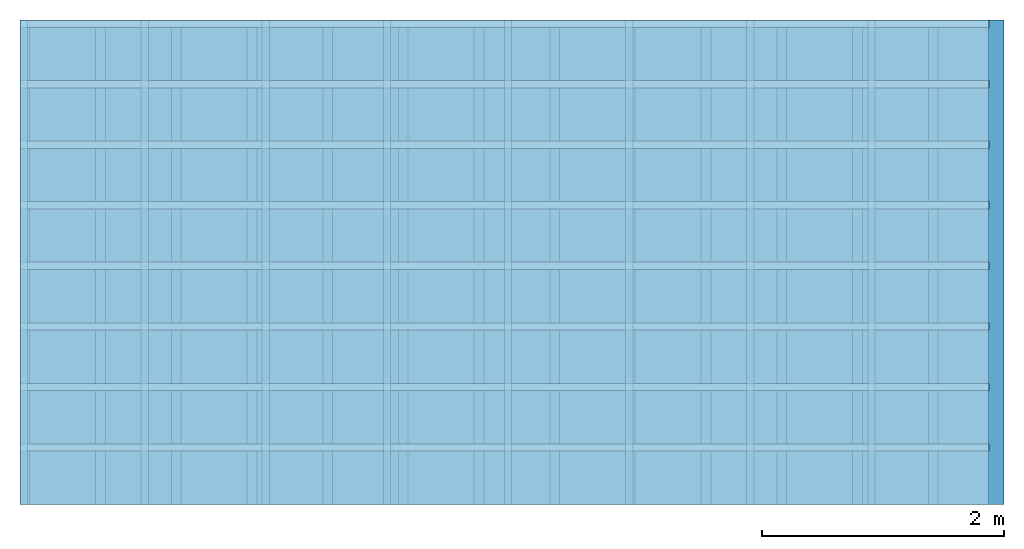
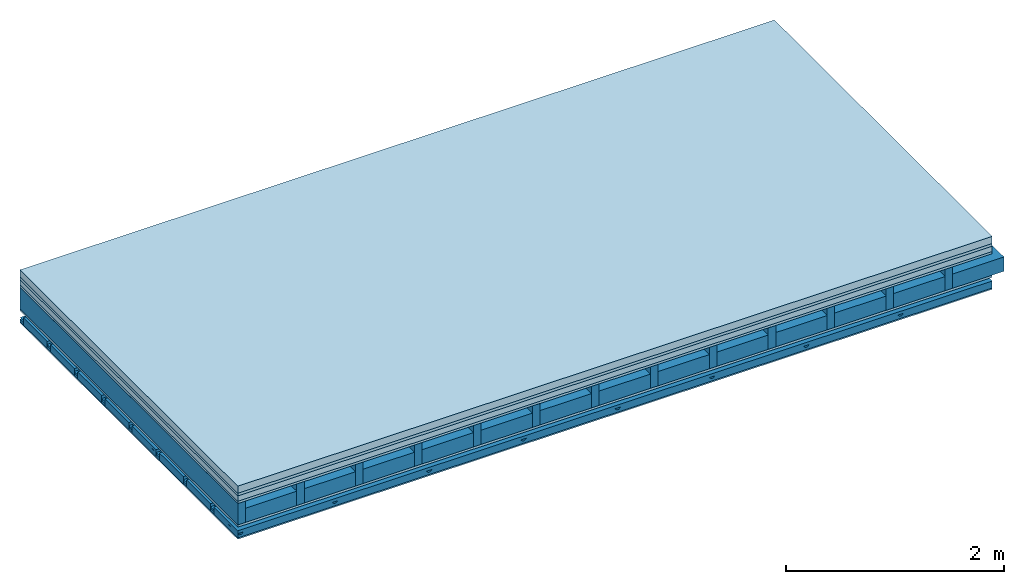
# One storey: 6 plates, 5 members, 1 element without a shape of its own.
"""IFC4 building model written with IfcOpenShell, lengths in metres."""

from ifc_helpers import new_model, si_unit, derived_unit, direction, frame, frame_2d, origin, origin_with_axes, place, context, project, spatial, polyline, rectangle, outline, extrude, material, layer, layer_set, type_object, element, aggregate, save


model = new_model("IFC4")

# Units and contexts
plan_context = context("Plan", 3, precision=1e-05, world=origin(), true_north=direction((0.0, 1.0)))
model_context = context("Model", 3, precision=1e-05, world=origin(), true_north=direction((0.0, 1.0)))
ifc_project = project(units=[si_unit("LENGTHUNIT", "METRE"), derived_unit("SOUNDPRESSUREUNIT", [(si_unit("PRESSUREUNIT", "PASCAL", prefix="MICRO"), 0)]), si_unit("ENERGYUNIT", "JOULE", prefix="MEGA"), si_unit("MASSUNIT", "GRAM", prefix="KILO"), derived_unit("THERMALTRANSMITTANCEUNIT", [(si_unit("POWERUNIT", "WATT"), 1), (si_unit("AREAUNIT", "SQUARE_METRE"), -1), (si_unit("THERMODYNAMICTEMPERATUREUNIT", "KELVIN"), -1)]), derived_unit("AREADENSITYUNIT", [(si_unit("MASSUNIT", "GRAM", prefix="KILO"), 1), (si_unit("AREAUNIT", "SQUARE_METRE"), -1)]), derived_unit("USERDEFINED", [(si_unit("ENERGYUNIT", "JOULE", prefix="MEGA"), 1), (si_unit("AREAUNIT", "SQUARE_METRE"), -1)])], contexts=[plan_context, model_context])

# Site, building, storey
site = spatial("IfcSite", under=ifc_project)
building_placement = place(None, origin())
building = spatial("IfcBuilding", under=site, at=building_placement)
storey_placement = place(building_placement, origin())
storey = spatial("IfcBuildingStorey", under=building, at=storey_placement)

# Slab, members, plates
ifc_material_1 = material(Name="Cement screed", Category="04.006")
ifc_layer_1 = layer(ifc_material_1, 0.08, Name="On-material")
ifc_material_2 = material()
ifc_layer_2 = layer(ifc_material_2, 0.03, Name="Impact sound insulation")
ifc_material_3 = material(Name="Cement panels, glued on sub-floor", Category="02.007")
ifc_layer_3 = layer(ifc_material_3, 0.06, Name="on Supporting structure")
ifc_material_4 = material(Category="07.001")
ifc_layer_4 = layer(ifc_material_4, 0.025, Name="Sub-floor")
ifc_material_5 = material(Name="Rigid, of the art")
ifc_layer_5 = layer(ifc_material_5, 0.0, Name="Bond")
ifc_layer_6 = layer(None, 0.24, Name="Supporting structure")
ifc_layer_7 = layer(ifc_material_5, 0.0, Name="Bond")
ifc_layer_8 = layer(ifc_material_4, 0.025, Name="Lower layer 1")
ifc_layer_9 = layer(None, 0.093, Name="Coupling")
ifc_layer_10 = layer(None, 0.027, Name="Battens / profiles")
ifc_material_6 = material(Category="03.007")
ifc_layer_11 = layer(ifc_material_6, 0.015, Name="Ceiling covering 1st layer")
ifc_material_7 = material(Name="Glued joints")
ifc_layer_12 = layer(ifc_material_7, 0.0, Name="Surface / treatment")
ifc_layer_set = layer_set([ifc_layer_1, ifc_layer_2, ifc_layer_3, ifc_layer_4, ifc_layer_5, ifc_layer_6, ifc_layer_7, ifc_layer_8, ifc_layer_9, ifc_layer_10, ifc_layer_11, ifc_layer_12])
slab_type = type_object("IfcSlabType", Name="A0513", PredefinedType="NOTDEFINED", material=ifc_layer_set)
slab_placement = place(None, frame((0.0, 0.0, 0.0), z_axis=(0.0, 0.0, -1.0), x_axis=(1.0, 0.0, 0.0)))
slab = element("IfcSlab", 1, at=slab_placement, inside=storey, type_object=slab_type, material=ifc_layer_set, Name="Slab #1")
ifc_material_8 = material()
member_1_placement = place(slab_placement, origin())
member_1 = element("IfcMember", 2, at=member_1_placement, material=ifc_material_8, Name="Supporting structure", context=plan_context, shape_type="SweptSolid", body=[
    extrude(rectangle(XDim=0.08, YDim=0.24, at=frame_2d((0.04, 0.12), x_axis=(1.0, 0.0))), frame((0.0, 4.0, 0.195), z_axis=(0.0, -1.0, 0.0), x_axis=(1.0, 0.0, 0.0)), (0.0, 0.0, 1.0), 4.0),
    extrude(rectangle(XDim=0.08, YDim=0.24, at=frame_2d((0.04, 0.12), x_axis=(1.0, 0.0))), frame((0.625, 4.0, 0.195), z_axis=(0.0, -1.0, 0.0), x_axis=(1.0, 0.0, 0.0)), (0.0, 0.0, 1.0), 4.0),
    extrude(rectangle(XDim=0.08, YDim=0.24, at=frame_2d((0.04, 0.12), x_axis=(1.0, 0.0))), frame((1.25, 4.0, 0.195), z_axis=(0.0, -1.0, 0.0), x_axis=(1.0, 0.0, 0.0)), (0.0, 0.0, 1.0), 4.0),
    extrude(rectangle(XDim=0.08, YDim=0.24, at=frame_2d((0.04, 0.12), x_axis=(1.0, 0.0))), frame((1.875, 4.0, 0.195), z_axis=(0.0, -1.0, 0.0), x_axis=(1.0, 0.0, 0.0)), (0.0, 0.0, 1.0), 4.0),
    extrude(rectangle(XDim=0.08, YDim=0.24, at=frame_2d((0.04, 0.12), x_axis=(1.0, 0.0))), frame((2.5, 4.0, 0.195), z_axis=(0.0, -1.0, 0.0), x_axis=(1.0, 0.0, 0.0)), (0.0, 0.0, 1.0), 4.0),
    extrude(rectangle(XDim=0.08, YDim=0.24, at=frame_2d((0.04, 0.12), x_axis=(1.0, 0.0))), frame((3.125, 4.0, 0.195), z_axis=(0.0, -1.0, 0.0), x_axis=(1.0, 0.0, 0.0)), (0.0, 0.0, 1.0), 4.0),
    extrude(rectangle(XDim=0.08, YDim=0.24, at=frame_2d((0.04, 0.12), x_axis=(1.0, 0.0))), frame((3.75, 4.0, 0.195), z_axis=(0.0, -1.0, 0.0), x_axis=(1.0, 0.0, 0.0)), (0.0, 0.0, 1.0), 4.0),
    extrude(rectangle(XDim=0.08, YDim=0.24, at=frame_2d((0.04, 0.12), x_axis=(1.0, 0.0))), frame((4.375, 4.0, 0.195), z_axis=(0.0, -1.0, 0.0), x_axis=(1.0, 0.0, 0.0)), (0.0, 0.0, 1.0), 4.0),
    extrude(rectangle(XDim=0.08, YDim=0.24, at=frame_2d((0.04, 0.12), x_axis=(1.0, 0.0))), frame((5.0, 4.0, 0.195), z_axis=(0.0, -1.0, 0.0), x_axis=(1.0, 0.0, 0.0)), (0.0, 0.0, 1.0), 4.0),
    extrude(rectangle(XDim=0.08, YDim=0.24, at=frame_2d((0.04, 0.12), x_axis=(1.0, 0.0))), frame((5.625, 4.0, 0.195), z_axis=(0.0, -1.0, 0.0), x_axis=(1.0, 0.0, 0.0)), (0.0, 0.0, 1.0), 4.0),
    extrude(rectangle(XDim=0.08, YDim=0.24, at=frame_2d((0.04, 0.12), x_axis=(1.0, 0.0))), frame((6.25, 4.0, 0.195), z_axis=(0.0, -1.0, 0.0), x_axis=(1.0, 0.0, 0.0)), (0.0, 0.0, 1.0), 4.0),
    extrude(rectangle(XDim=0.08, YDim=0.24, at=frame_2d((0.04, 0.12), x_axis=(1.0, 0.0))), frame((6.875, 4.0, 0.195), z_axis=(0.0, -1.0, 0.0), x_axis=(1.0, 0.0, 0.0)), (0.0, 0.0, 1.0), 4.0),
    extrude(rectangle(XDim=0.08, YDim=0.24, at=frame_2d((0.04, 0.12), x_axis=(1.0, 0.0))), frame((7.5, 4.0, 0.195), z_axis=(0.0, -1.0, 0.0), x_axis=(1.0, 0.0, 0.0)), (0.0, 0.0, 1.0), 4.0),
])
ifc_material_9 = material()
member_2_placement = place(slab_placement, origin())
member_2 = element("IfcMember", 3, at=member_2_placement, material=ifc_material_9, Name="Cavity", context=plan_context, shape_type="SweptSolid", body=[
    extrude(rectangle(XDim=0.545, YDim=0.16, at=frame_2d((0.2725, 0.08), x_axis=(1.0, 0.0))), frame((0.08, 4.0, 0.275), z_axis=(0.0, -1.0, 0.0), x_axis=(1.0, 0.0, 0.0)), (0.0, 0.0, 1.0), 4.0),
    extrude(rectangle(XDim=0.545, YDim=0.16, at=frame_2d((0.2725, 0.08), x_axis=(1.0, 0.0))), frame((0.705, 4.0, 0.275), z_axis=(0.0, -1.0, 0.0), x_axis=(1.0, 0.0, 0.0)), (0.0, 0.0, 1.0), 4.0),
    extrude(rectangle(XDim=0.545, YDim=0.16, at=frame_2d((0.2725, 0.08), x_axis=(1.0, 0.0))), frame((1.33, 4.0, 0.275), z_axis=(0.0, -1.0, 0.0), x_axis=(1.0, 0.0, 0.0)), (0.0, 0.0, 1.0), 4.0),
    extrude(rectangle(XDim=0.545, YDim=0.16, at=frame_2d((0.2725, 0.08), x_axis=(1.0, 0.0))), frame((1.955, 4.0, 0.275), z_axis=(0.0, -1.0, 0.0), x_axis=(1.0, 0.0, 0.0)), (0.0, 0.0, 1.0), 4.0),
    extrude(rectangle(XDim=0.545, YDim=0.16, at=frame_2d((0.2725, 0.08), x_axis=(1.0, 0.0))), frame((2.58, 4.0, 0.275), z_axis=(0.0, -1.0, 0.0), x_axis=(1.0, 0.0, 0.0)), (0.0, 0.0, 1.0), 4.0),
    extrude(rectangle(XDim=0.545, YDim=0.16, at=frame_2d((0.2725, 0.08), x_axis=(1.0, 0.0))), frame((3.205, 4.0, 0.275), z_axis=(0.0, -1.0, 0.0), x_axis=(1.0, 0.0, 0.0)), (0.0, 0.0, 1.0), 4.0),
    extrude(rectangle(XDim=0.545, YDim=0.16, at=frame_2d((0.2725, 0.08), x_axis=(1.0, 0.0))), frame((3.83, 4.0, 0.275), z_axis=(0.0, -1.0, 0.0), x_axis=(1.0, 0.0, 0.0)), (0.0, 0.0, 1.0), 4.0),
    extrude(rectangle(XDim=0.545, YDim=0.16, at=frame_2d((0.2725, 0.08), x_axis=(1.0, 0.0))), frame((4.455, 4.0, 0.275), z_axis=(0.0, -1.0, 0.0), x_axis=(1.0, 0.0, 0.0)), (0.0, 0.0, 1.0), 4.0),
    extrude(rectangle(XDim=0.545, YDim=0.16, at=frame_2d((0.2725, 0.08), x_axis=(1.0, 0.0))), frame((5.08, 4.0, 0.275), z_axis=(0.0, -1.0, 0.0), x_axis=(1.0, 0.0, 0.0)), (0.0, 0.0, 1.0), 4.0),
    extrude(rectangle(XDim=0.545, YDim=0.16, at=frame_2d((0.2725, 0.08), x_axis=(1.0, 0.0))), frame((5.705, 4.0, 0.275), z_axis=(0.0, -1.0, 0.0), x_axis=(1.0, 0.0, 0.0)), (0.0, 0.0, 1.0), 4.0),
    extrude(rectangle(XDim=0.545, YDim=0.16, at=frame_2d((0.2725, 0.08), x_axis=(1.0, 0.0))), frame((6.33, 4.0, 0.275), z_axis=(0.0, -1.0, 0.0), x_axis=(1.0, 0.0, 0.0)), (0.0, 0.0, 1.0), 4.0),
    extrude(rectangle(XDim=0.545, YDim=0.16, at=frame_2d((0.2725, 0.08), x_axis=(1.0, 0.0))), frame((6.955, 4.0, 0.275), z_axis=(0.0, -1.0, 0.0), x_axis=(1.0, 0.0, 0.0)), (0.0, 0.0, 1.0), 4.0),
    extrude(rectangle(XDim=0.545, YDim=0.16, at=frame_2d((0.2725, 0.08), x_axis=(1.0, 0.0))), frame((7.58, 4.0, 0.275), z_axis=(0.0, -1.0, 0.0), x_axis=(1.0, 0.0, 0.0)), (0.0, 0.0, 1.0), 4.0),
])
ifc_material_10 = material()
member_3_placement = place(slab_placement, origin())
member_3 = element("IfcMember", 4, at=member_3_placement, material=ifc_material_10, Name="Coupling", context=plan_context, shape_type="SweptSolid", body=[
    extrude(outline(polyline([(0.0, 0.0), (0.06, 0.0), (0.04, 0.02), (0.02, 0.02), (0.0, 0.0)])), frame((0.0, 4.0, 0.533), z_axis=(0.0, -1.0, 0.0), x_axis=(1.0, 0.0, 0.0)), (0.0, 0.0, 1.0), 4.0),
    extrude(outline(polyline([(0.0, 0.0), (0.06, 0.0), (0.04, 0.02), (0.02, 0.02), (0.0, 0.0)])), frame((1.0, 4.0, 0.533), z_axis=(0.0, -1.0, 0.0), x_axis=(1.0, 0.0, 0.0)), (0.0, 0.0, 1.0), 4.0),
    extrude(outline(polyline([(0.0, 0.0), (0.06, 0.0), (0.04, 0.02), (0.02, 0.02), (0.0, 0.0)])), frame((2.0, 4.0, 0.533), z_axis=(0.0, -1.0, 0.0), x_axis=(1.0, 0.0, 0.0)), (0.0, 0.0, 1.0), 4.0),
    extrude(outline(polyline([(0.0, 0.0), (0.06, 0.0), (0.04, 0.02), (0.02, 0.02), (0.0, 0.0)])), frame((3.0, 4.0, 0.533), z_axis=(0.0, -1.0, 0.0), x_axis=(1.0, 0.0, 0.0)), (0.0, 0.0, 1.0), 4.0),
    extrude(outline(polyline([(0.0, 0.0), (0.06, 0.0), (0.04, 0.02), (0.02, 0.02), (0.0, 0.0)])), frame((4.0, 4.0, 0.533), z_axis=(0.0, -1.0, 0.0), x_axis=(1.0, 0.0, 0.0)), (0.0, 0.0, 1.0), 4.0),
    extrude(outline(polyline([(0.0, 0.0), (0.06, 0.0), (0.04, 0.02), (0.02, 0.02), (0.0, 0.0)])), frame((5.0, 4.0, 0.533), z_axis=(0.0, -1.0, 0.0), x_axis=(1.0, 0.0, 0.0)), (0.0, 0.0, 1.0), 4.0),
    extrude(outline(polyline([(0.0, 0.0), (0.06, 0.0), (0.04, 0.02), (0.02, 0.02), (0.0, 0.0)])), frame((6.0, 4.0, 0.533), z_axis=(0.0, -1.0, 0.0), x_axis=(1.0, 0.0, 0.0)), (0.0, 0.0, 1.0), 4.0),
    extrude(outline(polyline([(0.0, 0.0), (0.06, 0.0), (0.04, 0.02), (0.02, 0.02), (0.0, 0.0)])), frame((7.0, 4.0, 0.533), z_axis=(0.0, -1.0, 0.0), x_axis=(1.0, 0.0, 0.0)), (0.0, 0.0, 1.0), 4.0),
])
ifc_material_11 = material()
member_4_placement = place(slab_placement, origin())
member_4 = element("IfcMember", 5, at=member_4_placement, material=ifc_material_11, Name="Battens / profiles", context=plan_context, shape_type="SweptSolid", body=[
    extrude(rectangle(XDim=0.06, YDim=0.027, at=frame_2d((0.03, 0.0135), x_axis=(1.0, 0.0))), frame((0.0, 0.0, 0.553), z_axis=(1.0, 0.0, 0.0), x_axis=(0.0, 1.0, 0.0)), (0.0, 0.0, 1.0), 8.0),
    extrude(rectangle(XDim=0.06, YDim=0.027, at=frame_2d((0.03, 0.0135), x_axis=(1.0, 0.0))), frame((0.0, 0.5, 0.553), z_axis=(1.0, 0.0, 0.0), x_axis=(0.0, 1.0, 0.0)), (0.0, 0.0, 1.0), 8.0),
    extrude(rectangle(XDim=0.06, YDim=0.027, at=frame_2d((0.03, 0.0135), x_axis=(1.0, 0.0))), frame((0.0, 1.0, 0.553), z_axis=(1.0, 0.0, 0.0), x_axis=(0.0, 1.0, 0.0)), (0.0, 0.0, 1.0), 8.0),
    extrude(rectangle(XDim=0.06, YDim=0.027, at=frame_2d((0.03, 0.0135), x_axis=(1.0, 0.0))), frame((0.0, 1.5, 0.553), z_axis=(1.0, 0.0, 0.0), x_axis=(0.0, 1.0, 0.0)), (0.0, 0.0, 1.0), 8.0),
    extrude(rectangle(XDim=0.06, YDim=0.027, at=frame_2d((0.03, 0.0135), x_axis=(1.0, 0.0))), frame((0.0, 2.0, 0.553), z_axis=(1.0, 0.0, 0.0), x_axis=(0.0, 1.0, 0.0)), (0.0, 0.0, 1.0), 8.0),
    extrude(rectangle(XDim=0.06, YDim=0.027, at=frame_2d((0.03, 0.0135), x_axis=(1.0, 0.0))), frame((0.0, 2.5, 0.553), z_axis=(1.0, 0.0, 0.0), x_axis=(0.0, 1.0, 0.0)), (0.0, 0.0, 1.0), 8.0),
    extrude(rectangle(XDim=0.06, YDim=0.027, at=frame_2d((0.03, 0.0135), x_axis=(1.0, 0.0))), frame((0.0, 3.0, 0.553), z_axis=(1.0, 0.0, 0.0), x_axis=(0.0, 1.0, 0.0)), (0.0, 0.0, 1.0), 8.0),
    extrude(rectangle(XDim=0.06, YDim=0.027, at=frame_2d((0.03, 0.0135), x_axis=(1.0, 0.0))), frame((0.0, 3.5, 0.553), z_axis=(1.0, 0.0, 0.0), x_axis=(0.0, 1.0, 0.0)), (0.0, 0.0, 1.0), 8.0),
])
member_5_placement = place(slab_placement, origin())
member_5 = element("IfcMember", 6, at=member_5_placement, material=ifc_material_9, Name="Cavity", context=plan_context, shape_type="SweptSolid", body=[
    extrude(rectangle(XDim=0.44, YDim=0.08, at=frame_2d((0.22, 0.04), x_axis=(1.0, 0.0))), frame((0.0, 0.06, 0.5), z_axis=(1.0, 0.0, 0.0), x_axis=(0.0, 1.0, 0.0)), (0.0, 0.0, 1.0), 8.0),
    extrude(rectangle(XDim=0.44, YDim=0.08, at=frame_2d((0.22, 0.04), x_axis=(1.0, 0.0))), frame((0.0, 0.56, 0.5), z_axis=(1.0, 0.0, 0.0), x_axis=(0.0, 1.0, 0.0)), (0.0, 0.0, 1.0), 8.0),
    extrude(rectangle(XDim=0.44, YDim=0.08, at=frame_2d((0.22, 0.04), x_axis=(1.0, 0.0))), frame((0.0, 1.06, 0.5), z_axis=(1.0, 0.0, 0.0), x_axis=(0.0, 1.0, 0.0)), (0.0, 0.0, 1.0), 8.0),
    extrude(rectangle(XDim=0.44, YDim=0.08, at=frame_2d((0.22, 0.04), x_axis=(1.0, 0.0))), frame((0.0, 1.56, 0.5), z_axis=(1.0, 0.0, 0.0), x_axis=(0.0, 1.0, 0.0)), (0.0, 0.0, 1.0), 8.0),
    extrude(rectangle(XDim=0.44, YDim=0.08, at=frame_2d((0.22, 0.04), x_axis=(1.0, 0.0))), frame((0.0, 2.06, 0.5), z_axis=(1.0, 0.0, 0.0), x_axis=(0.0, 1.0, 0.0)), (0.0, 0.0, 1.0), 8.0),
    extrude(rectangle(XDim=0.44, YDim=0.08, at=frame_2d((0.22, 0.04), x_axis=(1.0, 0.0))), frame((0.0, 2.56, 0.5), z_axis=(1.0, 0.0, 0.0), x_axis=(0.0, 1.0, 0.0)), (0.0, 0.0, 1.0), 8.0),
    extrude(rectangle(XDim=0.44, YDim=0.08, at=frame_2d((0.22, 0.04), x_axis=(1.0, 0.0))), frame((0.0, 3.06, 0.5), z_axis=(1.0, 0.0, 0.0), x_axis=(0.0, 1.0, 0.0)), (0.0, 0.0, 1.0), 8.0),
    extrude(rectangle(XDim=0.44, YDim=0.08, at=frame_2d((0.22, 0.04), x_axis=(1.0, 0.0))), frame((0.0, 3.56, 0.5), z_axis=(1.0, 0.0, 0.0), x_axis=(0.0, 1.0, 0.0)), (0.0, 0.0, 1.0), 8.0),
])
plate_1_placement = place(slab_placement, origin())
plate_1 = element("IfcPlate", 7, at=plate_1_placement, material=ifc_material_1, Name="On-material", context=plan_context, shape_type="SweptSolid", body=[
    extrude(rectangle(XDim=8.0, YDim=4.0, at=frame_2d((4.0, 2.0), x_axis=(1.0, 0.0))), origin_with_axes(), (0.0, 0.0, 1.0), 0.08),
])
plate_2_placement = place(slab_placement, origin())
plate_2 = element("IfcPlate", 8, at=plate_2_placement, material=ifc_material_2, Name="Impact sound insulation", context=plan_context, shape_type="SweptSolid", body=[
    extrude(rectangle(XDim=8.0, YDim=4.0, at=frame_2d((4.0, 2.0), x_axis=(1.0, 0.0))), frame((0.0, 0.0, 0.08), z_axis=(0.0, 0.0, 1.0), x_axis=(1.0, 0.0, 0.0)), (0.0, 0.0, 1.0), 0.03),
])
plate_3_placement = place(slab_placement, origin())
plate_3 = element("IfcPlate", 9, at=plate_3_placement, material=ifc_material_3, Name="on Supporting structure", context=plan_context, shape_type="SweptSolid", body=[
    extrude(rectangle(XDim=8.0, YDim=4.0, at=frame_2d((4.0, 2.0), x_axis=(1.0, 0.0))), frame((0.0, 0.0, 0.11), z_axis=(0.0, 0.0, 1.0), x_axis=(1.0, 0.0, 0.0)), (0.0, 0.0, 1.0), 0.06),
])
plate_4_placement = place(slab_placement, origin())
plate_4 = element("IfcPlate", 10, at=plate_4_placement, material=ifc_material_4, Name="Sub-floor", context=plan_context, shape_type="SweptSolid", body=[
    extrude(rectangle(XDim=8.0, YDim=4.0, at=frame_2d((4.0, 2.0), x_axis=(1.0, 0.0))), frame((0.0, 0.0, 0.17), z_axis=(0.0, 0.0, 1.0), x_axis=(1.0, 0.0, 0.0)), (0.0, 0.0, 1.0), 0.025),
])
plate_5_placement = place(slab_placement, origin())
plate_5 = element("IfcPlate", 11, at=plate_5_placement, material=ifc_material_4, Name="Lower layer 1", context=plan_context, shape_type="SweptSolid", body=[
    extrude(rectangle(XDim=8.0, YDim=4.0, at=frame_2d((4.0, 2.0), x_axis=(1.0, 0.0))), frame((0.0, 0.0, 0.435), z_axis=(0.0, 0.0, 1.0), x_axis=(1.0, 0.0, 0.0)), (0.0, 0.0, 1.0), 0.025),
])
plate_6_placement = place(slab_placement, origin())
plate_6 = element("IfcPlate", 12, at=plate_6_placement, material=ifc_material_6, Name="Ceiling covering 1st layer", context=plan_context, shape_type="SweptSolid", body=[
    extrude(rectangle(XDim=8.0, YDim=4.0, at=frame_2d((4.0, 2.0), x_axis=(1.0, 0.0))), frame((0.0, 0.0, 0.58), z_axis=(0.0, 0.0, 1.0), x_axis=(1.0, 0.0, 0.0)), (0.0, 0.0, 1.0), 0.015),
])
aggregate(slab, [plate_1, plate_2, plate_3, plate_4, member_1, member_2, plate_5, member_3, member_4, member_5, plate_6])

save(model, "model.ifc")
